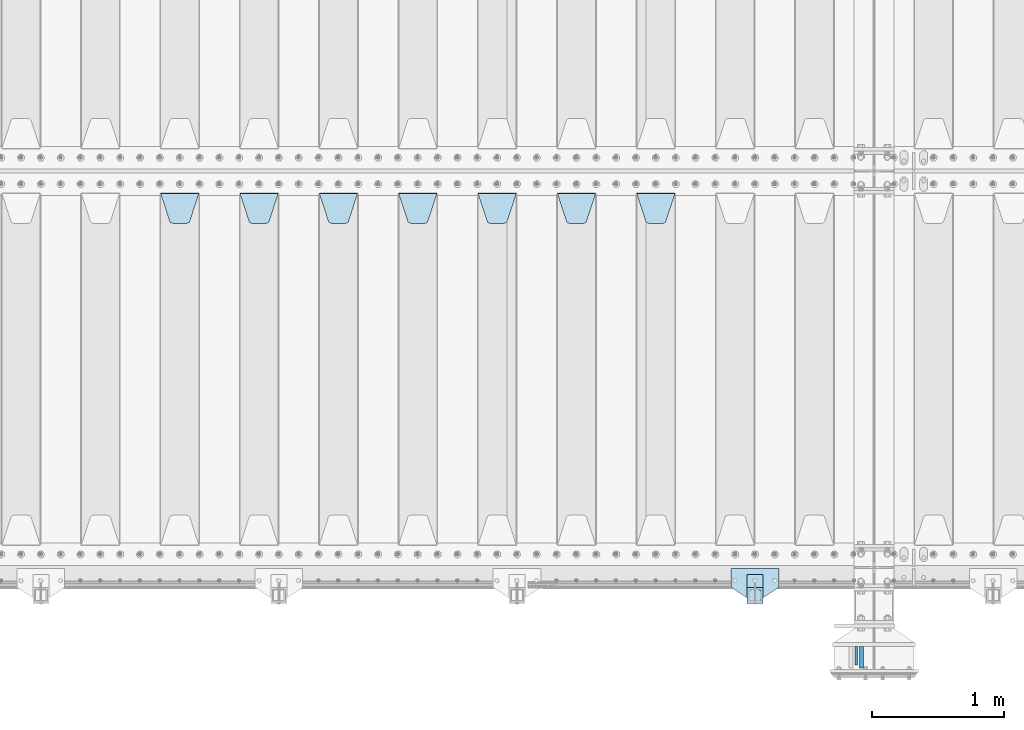
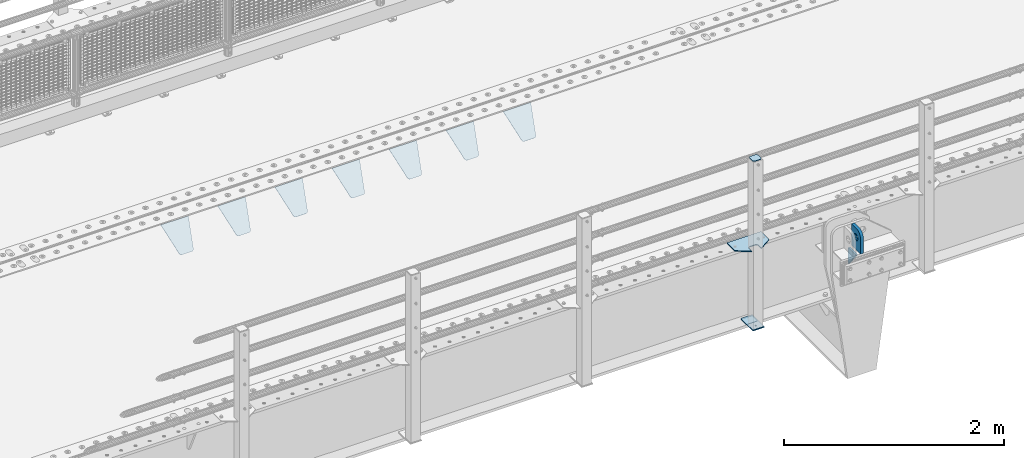
# One storey, part 177 of 208: 13 plates.
"""IFC2X3 building model written with IfcOpenShell, lengths in millimetres."""

from ifc_helpers import new_model, si_unit, frame, origin_with_axes, place, context, subcontext, project, spatial, faceted_brep, material, type_object, element, save


model = new_model("IFC2X3")

# Units and contexts
model_context = context("Model", 3, precision=1e-05, world=origin_with_axes())
body_context = subcontext(model_context, "Body", "Model", "MODEL_VIEW")
ifc_project = project(units=[si_unit("LENGTHUNIT", "METRE", prefix="MILLI"), si_unit("AREAUNIT", "SQUARE_METRE"), si_unit("VOLUMEUNIT", "CUBIC_METRE"), si_unit("MASSUNIT", "GRAM", prefix="KILO"), si_unit("TIMEUNIT", "SECOND"), si_unit("PLANEANGLEUNIT", "RADIAN"), si_unit("SOLIDANGLEUNIT", "STERADIAN"), si_unit("THERMODYNAMICTEMPERATUREUNIT", "DEGREE_CELSIUS"), si_unit("LUMINOUSINTENSITYUNIT", "LUMEN")], contexts=[model_context])

# Site, building, storey
site_placement = place(None, origin_with_axes())
site = spatial("IfcSite", under=ifc_project, at=site_placement, CompositionType="ELEMENT")
building_placement = place(site_placement, origin_with_axes())
building = spatial("IfcBuilding", under=site, at=building_placement, Name="Standard", CompositionType="ELEMENT")
storey_placement = place(building_placement, origin_with_axes())
storey = spatial("IfcBuildingStorey", under=building, at=storey_placement, Name="Undefined", CompositionType="ELEMENT", Elevation=0.0)

# Plates
ifc_material_1 = material(Name="STEEL/S355N")
plate_type_1 = type_object("IfcPlateType", PredefinedType="NOTDEFINED")
plate_1_placement = place(storey_placement, frame((-30335.5000001149, -734.999999963963, -14.0000182219301), z_axis=(0.0, 0.0, -1.0), x_axis=(0.0, 1.0, 0.0)))
element("IfcPlate", 1, at=plate_1_placement, inside=storey, type_object=plate_type_1, material=ifc_material_1, context=body_context, shape_type="Brep", body=[
    faceted_brep([(0.0, -10.0, 0.0), (140.0, -10.0, 180.0), (140.0, 10.0, 180.0), (0.0, 10.0, 0.0), (140.0, -10.0, -1.81898940354586e-12), (140.0, 10.0, -1.81898940354586e-12)], [[[0, 1, 2, 3]], [[1, 4, 5, 2]], [[4, 0, 3, 5]], [[5, 3, 2]], [[4, 1, 0]]]),
])
plate_type_2 = type_object("IfcPlateType", PredefinedType="NOTDEFINED")
plate_2_placement = place(storey_placement, frame((-30295.5000001165, -594.999999963945, -1.82219628186431e-05), z_axis=(0.0, -1.0, 0.0), x_axis=(0.0, 0.0, 1.0)))
element("IfcPlate", 2, at=plate_2_placement, inside=storey, type_object=plate_type_2, material=ifc_material_1, context=body_context, shape_type="Brep", body=[
    faceted_brep([(125.840713002497, -14.9999995435392, 45.8164574470834), (125.840713002497, 15.0000004564608, 45.8164571470834), (113.837049096103, 15.0000005366674, 53.8370489460988), (113.837049096103, -14.9999994633326, 53.8370492460988), (105.816457297088, 15.0000006567025, 65.8407128524926), (105.816457297088, -14.9999993432975, 65.8407131524926), (103.000000000005, 15.0000007982962, 79.999999850001), (103.000000000005, -14.9999992017038, 80.000000150001), (105.816457297088, 15.00000093989, 94.1592868475093), (105.816457297088, -14.99999906011, 94.1592871475093), (113.837049096103, 15.0000010599251, 106.162950753903), (113.837049096103, -14.9999989400749, 106.162951053903), (125.840713002497, 15.0000011401316, 114.183542552919), (125.840713002497, -14.9999988598684, 114.183542852919), (140.000000000005, 15.0000011682969, 116.999999850001), (140.000000000005, -14.9999988317031, 117.000000150001), (154.159286997514, 15.0000011401316, 114.183542552919), (154.159286997514, -14.9999988598684, 114.183542852919), (166.162950903908, 15.0000010599251, 106.162950753903), (166.162950903908, -14.9999989400749, 106.162951053903), (174.183542702923, 15.00000093989, 94.1592868475093), (174.183542702923, -14.99999906011, 94.1592871475093), (177.000000000005, 15.0000007982962, 79.999999850001), (177.000000000005, -14.9999992017038, 80.000000150001), (174.183542702923, 15.0000006567025, 65.8407128524927), (174.183542702923, -14.9999993432975, 65.8407131524928), (166.162950903908, 15.0000005366674, 53.8370489460988), (166.162950903908, -14.9999994633326, 53.8370492460988), (154.159286997514, 15.0000004564608, 45.8164571470834), (154.159286997514, -14.9999995435392, 45.8164574470834), (140.000000000005, 15.0000004282956, 42.999999850001), (140.000000000005, -14.9999995717044, 43.000000150001), (240.000015258789, -14.9999999999964, -2.06341610464733e-10), (240.001666876698, -15.0, 94.9959403776224), (237.616787699976, -15.0, 113.113322498935), (230.624045898169, -15.0, 129.996116868067), (219.499985670386, -14.9999999999964, 144.493787979863), (205.002693976271, -14.9999999999964, 155.618342674451), (188.120138118986, -15.0, 162.611660295065), (170.002837349484, -15.0, 164.997157401461), (-1.40620068123098e-06, -15.0, 165.0), (0.0, -15.0, 0.0), (0.0, 15.0, 0.0), (240.000015258789, 15.0000000000036, -2.06341610464733e-10), (240.001666876698, 15.0, 94.9959403776223), (237.616787699976, 15.0, 113.113322498935), (230.624045898169, 15.0, 129.996116868067), (219.499985670386, 15.0000000000036, 144.493787979863), (205.002693976271, 15.0000000000036, 155.618342674451), (188.120138118986, 15.0, 162.611660295065), (170.002837349484, 15.0, 164.997157401461), (-1.40620068123098e-06, 15.0, 165.0)], [[[0, 1, 2, 3]], [[3, 2, 4, 5]], [[5, 4, 6, 7]], [[7, 6, 8, 9]], [[9, 8, 10, 11]], [[11, 10, 12, 13]], [[13, 12, 14, 15]], [[15, 14, 16, 17]], [[17, 16, 18, 19]], [[19, 18, 20, 21]], [[21, 20, 22, 23]], [[23, 22, 24, 25]], [[25, 24, 26, 27]], [[27, 26, 28, 29]], [[29, 28, 30, 31]], [[31, 30, 1, 0]], [[32, 33, 34, 35, 36, 37, 38, 39, 40, 41], [3, 5, 7, 9, 11, 13, 15, 17, 19, 21, 23, 25, 27, 29, 31, 0]], [[32, 41, 42, 43]], [[33, 32, 43, 44]], [[34, 33, 44, 45]], [[35, 34, 45, 46]], [[36, 35, 46, 47]], [[37, 36, 47, 48]], [[38, 37, 48, 49]], [[39, 38, 49, 50]], [[40, 39, 50, 51]], [[41, 40, 51, 42]], [[50, 49, 48, 47, 46, 45, 44, 43, 42, 51], [26, 24, 22, 20, 18, 16, 14, 12, 10, 8, 6, 4, 2, 1, 30, 28]]]),
])
plate_type_3 = type_object("IfcPlateType", PredefinedType="NOTDEFINED")
plate_3_placement = place(storey_placement, frame((-31995.0, 2831.76776695596, -1.76776695296758), z_axis=(0.0, -0.707106781186548, -0.707106781186547), x_axis=(1.0, 0.0, 0.0)))
element("IfcPlate", 3, at=plate_3_placement, inside=storey, type_object=plate_type_3, material=ifc_material_1, context=body_context, shape_type="Brep", body=[
    faceted_brep([(0.0, -2.5, 0.0), (69.345504679477, -2.5, 300.17173142483), (69.345504679477, 2.5, 300.17173142483), (0.0, 2.5, 0.0), (70.9274061199576, -2.5, 304.897442415399), (70.9274061199576, 2.5, 304.8974424154), (73.3818627772307, -2.5, 309.234538108527), (73.3818627772307, 2.5, 309.234538108527), (76.6187032999551, -2.5, 313.023683126103), (76.6187032999551, 2.5, 313.023683126103), (80.5190132704993, -2.5, 316.125672595371), (80.5190132704993, 2.5, 316.125672595371), (84.9395038596849, -2.5, 318.426546230476), (84.9395038596849, 2.50000000000091, 318.426546230476), (89.7177759439219, -2.5, 319.841774983275), (89.7177759439219, 2.50000000000091, 319.841774983275), (94.678286292652, -2.49999999999909, 320.319366455078), (94.678286292652, 2.5, 320.319366455078), (195.321713707348, -2.49999999999909, 320.319366455078), (195.321713707348, 2.5, 320.319366455078), (200.282224056078, -2.5, 319.841774983275), (200.282224056078, 2.5, 319.841774983274), (205.060496140315, -2.5, 318.426546230475), (205.060496140315, 2.5, 318.426546230475), (209.480986729501, -2.5, 316.125672595371), (209.480986729501, 2.50000000000091, 316.125672595371), (213.381296700045, -2.5, 313.023683126102), (213.381296700045, 2.5, 313.023683126102), (216.618137222769, -2.5, 309.234538108526), (216.618137222769, 2.5, 309.234538108527), (219.072593880042, -2.5, 304.897442415399), (219.072593880042, 2.5, 304.897442415399), (220.654495320523, -2.5, 300.17173142483), (220.654495320523, 2.5, 300.17173142483), (290.0, -2.5, 0.0), (290.0, 2.5, 0.0)], [[[0, 1, 2, 3]], [[1, 4, 5, 2]], [[4, 6, 7, 5]], [[6, 8, 9, 7]], [[8, 10, 11, 9]], [[10, 12, 13, 11]], [[12, 14, 15, 13]], [[14, 16, 17, 15]], [[16, 18, 19, 17]], [[18, 20, 21, 19]], [[20, 22, 23, 21]], [[22, 24, 25, 23]], [[24, 26, 27, 25]], [[26, 28, 29, 27]], [[28, 30, 31, 29]], [[30, 32, 33, 31]], [[32, 34, 35, 33]], [[34, 0, 3, 35]], [[5, 7, 9, 11, 13, 15, 17, 19, 21, 23, 25, 27, 29, 31, 33, 35, 3, 2]], [[34, 32, 30, 28, 26, 24, 22, 20, 18, 16, 14, 12, 10, 8, 6, 4, 1, 0]]]),
])
plate_4_placement = place(storey_placement, frame((-32595.0, 2831.76776695596, -1.76776695296758), z_axis=(0.0, -0.707106781186548, -0.707106781186547), x_axis=(1.0, 0.0, 0.0)))
element("IfcPlate", 4, at=plate_4_placement, inside=storey, type_object=plate_type_3, material=ifc_material_1, context=body_context, shape_type="Brep", body=[
    faceted_brep([(0.0, -2.5, 0.0), (69.345504679477, -2.5, 300.17173142483), (69.345504679477, 2.5, 300.17173142483), (0.0, 2.5, 0.0), (70.9274061199576, -2.5, 304.897442415399), (70.9274061199576, 2.5, 304.8974424154), (73.3818627772307, -2.5, 309.234538108527), (73.3818627772307, 2.5, 309.234538108527), (76.6187032999551, -2.5, 313.023683126103), (76.6187032999551, 2.5, 313.023683126103), (80.5190132704993, -2.5, 316.125672595371), (80.5190132704993, 2.5, 316.125672595371), (84.9395038596849, -2.5, 318.426546230476), (84.9395038596849, 2.50000000000091, 318.426546230476), (89.7177759439219, -2.5, 319.841774983275), (89.7177759439219, 2.50000000000091, 319.841774983275), (94.678286292652, -2.49999999999909, 320.319366455078), (94.678286292652, 2.5, 320.319366455078), (195.321713707348, -2.49999999999909, 320.319366455078), (195.321713707348, 2.5, 320.319366455078), (200.282224056078, -2.5, 319.841774983275), (200.282224056078, 2.5, 319.841774983274), (205.060496140315, -2.5, 318.426546230475), (205.060496140315, 2.5, 318.426546230475), (209.480986729501, -2.5, 316.125672595371), (209.480986729501, 2.50000000000091, 316.125672595371), (213.381296700045, -2.5, 313.023683126102), (213.381296700045, 2.5, 313.023683126102), (216.618137222769, -2.5, 309.234538108526), (216.618137222769, 2.5, 309.234538108527), (219.072593880042, -2.5, 304.897442415399), (219.072593880042, 2.5, 304.897442415399), (220.654495320523, -2.5, 300.17173142483), (220.654495320523, 2.5, 300.17173142483), (290.0, -2.5, 0.0), (290.0, 2.5, 0.0)], [[[0, 1, 2, 3]], [[1, 4, 5, 2]], [[4, 6, 7, 5]], [[6, 8, 9, 7]], [[8, 10, 11, 9]], [[10, 12, 13, 11]], [[12, 14, 15, 13]], [[14, 16, 17, 15]], [[16, 18, 19, 17]], [[18, 20, 21, 19]], [[20, 22, 23, 21]], [[22, 24, 25, 23]], [[24, 26, 27, 25]], [[26, 28, 29, 27]], [[28, 30, 31, 29]], [[30, 32, 33, 31]], [[32, 34, 35, 33]], [[34, 0, 3, 35]], [[5, 7, 9, 11, 13, 15, 17, 19, 21, 23, 25, 27, 29, 31, 33, 35, 3, 2]], [[34, 32, 30, 28, 26, 24, 22, 20, 18, 16, 14, 12, 10, 8, 6, 4, 1, 0]]]),
])
plate_5_placement = place(storey_placement, frame((-33195.0, 2831.76776695596, -1.76776695296758), z_axis=(0.0, -0.707106781186548, -0.707106781186547), x_axis=(1.0, 0.0, 0.0)))
element("IfcPlate", 5, at=plate_5_placement, inside=storey, type_object=plate_type_3, material=ifc_material_1, context=body_context, shape_type="Brep", body=[
    faceted_brep([(0.0, -2.5, 0.0), (69.345504679477, -2.5, 300.17173142483), (69.345504679477, 2.5, 300.17173142483), (0.0, 2.5, 0.0), (70.9274061199576, -2.5, 304.897442415399), (70.9274061199576, 2.5, 304.8974424154), (73.3818627772307, -2.5, 309.234538108527), (73.3818627772307, 2.5, 309.234538108527), (76.6187032999551, -2.5, 313.023683126103), (76.6187032999551, 2.5, 313.023683126103), (80.5190132704993, -2.5, 316.125672595371), (80.5190132704993, 2.5, 316.125672595371), (84.9395038596849, -2.5, 318.426546230476), (84.9395038596849, 2.50000000000091, 318.426546230476), (89.7177759439219, -2.5, 319.841774983275), (89.7177759439219, 2.50000000000091, 319.841774983275), (94.678286292652, -2.49999999999909, 320.319366455078), (94.678286292652, 2.5, 320.319366455078), (195.321713707348, -2.49999999999909, 320.319366455078), (195.321713707348, 2.5, 320.319366455078), (200.282224056078, -2.5, 319.841774983275), (200.282224056078, 2.5, 319.841774983274), (205.060496140315, -2.5, 318.426546230475), (205.060496140315, 2.5, 318.426546230475), (209.480986729501, -2.5, 316.125672595371), (209.480986729501, 2.50000000000091, 316.125672595371), (213.381296700045, -2.5, 313.023683126102), (213.381296700045, 2.5, 313.023683126102), (216.618137222769, -2.5, 309.234538108526), (216.618137222769, 2.5, 309.234538108527), (219.072593880042, -2.5, 304.897442415399), (219.072593880042, 2.5, 304.897442415399), (220.654495320523, -2.5, 300.17173142483), (220.654495320523, 2.5, 300.17173142483), (290.0, -2.5, 0.0), (290.0, 2.5, 0.0)], [[[0, 1, 2, 3]], [[1, 4, 5, 2]], [[4, 6, 7, 5]], [[6, 8, 9, 7]], [[8, 10, 11, 9]], [[10, 12, 13, 11]], [[12, 14, 15, 13]], [[14, 16, 17, 15]], [[16, 18, 19, 17]], [[18, 20, 21, 19]], [[20, 22, 23, 21]], [[22, 24, 25, 23]], [[24, 26, 27, 25]], [[26, 28, 29, 27]], [[28, 30, 31, 29]], [[30, 32, 33, 31]], [[32, 34, 35, 33]], [[34, 0, 3, 35]], [[5, 7, 9, 11, 13, 15, 17, 19, 21, 23, 25, 27, 29, 31, 33, 35, 3, 2]], [[34, 32, 30, 28, 26, 24, 22, 20, 18, 16, 14, 12, 10, 8, 6, 4, 1, 0]]]),
])
plate_6_placement = place(storey_placement, frame((-33795.0, 2831.76776695596, -1.76776695296758), z_axis=(0.0, -0.707106781186548, -0.707106781186547), x_axis=(1.0, 0.0, 0.0)))
element("IfcPlate", 6, at=plate_6_placement, inside=storey, type_object=plate_type_3, material=ifc_material_1, context=body_context, shape_type="Brep", body=[
    faceted_brep([(0.0, -2.5, 0.0), (69.345504679477, -2.5, 300.17173142483), (69.345504679477, 2.5, 300.17173142483), (0.0, 2.5, 0.0), (70.9274061199576, -2.5, 304.897442415399), (70.9274061199576, 2.5, 304.8974424154), (73.3818627772307, -2.5, 309.234538108527), (73.3818627772307, 2.5, 309.234538108527), (76.6187032999551, -2.5, 313.023683126103), (76.6187032999551, 2.5, 313.023683126103), (80.5190132704993, -2.5, 316.125672595371), (80.5190132704993, 2.5, 316.125672595371), (84.9395038596849, -2.5, 318.426546230476), (84.9395038596849, 2.50000000000091, 318.426546230476), (89.7177759439219, -2.5, 319.841774983275), (89.7177759439219, 2.50000000000091, 319.841774983275), (94.678286292652, -2.49999999999909, 320.319366455078), (94.678286292652, 2.5, 320.319366455078), (195.321713707348, -2.49999999999909, 320.319366455078), (195.321713707348, 2.5, 320.319366455078), (200.282224056078, -2.5, 319.841774983275), (200.282224056078, 2.5, 319.841774983274), (205.060496140315, -2.5, 318.426546230475), (205.060496140315, 2.5, 318.426546230475), (209.480986729501, -2.5, 316.125672595371), (209.480986729501, 2.50000000000091, 316.125672595371), (213.381296700045, -2.5, 313.023683126102), (213.381296700045, 2.5, 313.023683126102), (216.618137222769, -2.5, 309.234538108526), (216.618137222769, 2.5, 309.234538108527), (219.072593880042, -2.5, 304.897442415399), (219.072593880042, 2.5, 304.897442415399), (220.654495320523, -2.5, 300.17173142483), (220.654495320523, 2.5, 300.17173142483), (290.0, -2.5, 0.0), (290.0, 2.5, 0.0)], [[[0, 1, 2, 3]], [[1, 4, 5, 2]], [[4, 6, 7, 5]], [[6, 8, 9, 7]], [[8, 10, 11, 9]], [[10, 12, 13, 11]], [[12, 14, 15, 13]], [[14, 16, 17, 15]], [[16, 18, 19, 17]], [[18, 20, 21, 19]], [[20, 22, 23, 21]], [[22, 24, 25, 23]], [[24, 26, 27, 25]], [[26, 28, 29, 27]], [[28, 30, 31, 29]], [[30, 32, 33, 31]], [[32, 34, 35, 33]], [[34, 0, 3, 35]], [[5, 7, 9, 11, 13, 15, 17, 19, 21, 23, 25, 27, 29, 31, 33, 35, 3, 2]], [[34, 32, 30, 28, 26, 24, 22, 20, 18, 16, 14, 12, 10, 8, 6, 4, 1, 0]]]),
])
plate_7_placement = place(storey_placement, frame((-34395.0, 2831.76776695596, -1.76776695296758), z_axis=(0.0, -0.707106781186548, -0.707106781186547), x_axis=(1.0, 0.0, 0.0)))
element("IfcPlate", 7, at=plate_7_placement, inside=storey, type_object=plate_type_3, material=ifc_material_1, context=body_context, shape_type="Brep", body=[
    faceted_brep([(0.0, -2.5, 0.0), (69.345504679477, -2.5, 300.17173142483), (69.345504679477, 2.5, 300.17173142483), (0.0, 2.5, 0.0), (70.9274061199576, -2.5, 304.897442415399), (70.9274061199576, 2.5, 304.8974424154), (73.3818627772307, -2.5, 309.234538108527), (73.3818627772307, 2.5, 309.234538108527), (76.6187032999551, -2.5, 313.023683126103), (76.6187032999551, 2.5, 313.023683126103), (80.5190132704993, -2.5, 316.125672595371), (80.5190132704993, 2.5, 316.125672595371), (84.9395038596849, -2.5, 318.426546230476), (84.9395038596849, 2.50000000000091, 318.426546230476), (89.7177759439219, -2.5, 319.841774983275), (89.7177759439219, 2.50000000000091, 319.841774983275), (94.678286292652, -2.49999999999909, 320.319366455078), (94.678286292652, 2.5, 320.319366455078), (195.321713707348, -2.49999999999909, 320.319366455078), (195.321713707348, 2.5, 320.319366455078), (200.282224056078, -2.5, 319.841774983275), (200.282224056078, 2.5, 319.841774983274), (205.060496140315, -2.5, 318.426546230475), (205.060496140315, 2.5, 318.426546230475), (209.480986729501, -2.5, 316.125672595371), (209.480986729501, 2.50000000000091, 316.125672595371), (213.381296700045, -2.5, 313.023683126102), (213.381296700045, 2.5, 313.023683126102), (216.618137222769, -2.5, 309.234538108526), (216.618137222769, 2.5, 309.234538108527), (219.072593880042, -2.5, 304.897442415399), (219.072593880042, 2.5, 304.897442415399), (220.654495320523, -2.5, 300.17173142483), (220.654495320523, 2.5, 300.17173142483), (290.0, -2.5, 0.0), (290.0, 2.5, 0.0)], [[[0, 1, 2, 3]], [[1, 4, 5, 2]], [[4, 6, 7, 5]], [[6, 8, 9, 7]], [[8, 10, 11, 9]], [[10, 12, 13, 11]], [[12, 14, 15, 13]], [[14, 16, 17, 15]], [[16, 18, 19, 17]], [[18, 20, 21, 19]], [[20, 22, 23, 21]], [[22, 24, 25, 23]], [[24, 26, 27, 25]], [[26, 28, 29, 27]], [[28, 30, 31, 29]], [[30, 32, 33, 31]], [[32, 34, 35, 33]], [[34, 0, 3, 35]], [[5, 7, 9, 11, 13, 15, 17, 19, 21, 23, 25, 27, 29, 31, 33, 35, 3, 2]], [[34, 32, 30, 28, 26, 24, 22, 20, 18, 16, 14, 12, 10, 8, 6, 4, 1, 0]]]),
])
plate_8_placement = place(storey_placement, frame((-34995.0, 2831.76776695596, -1.76776695296758), z_axis=(0.0, -0.707106781186548, -0.707106781186547), x_axis=(1.0, 0.0, 0.0)))
element("IfcPlate", 8, at=plate_8_placement, inside=storey, type_object=plate_type_3, material=ifc_material_1, context=body_context, shape_type="Brep", body=[
    faceted_brep([(0.0, -2.5, 0.0), (69.345504679477, -2.5, 300.17173142483), (69.345504679477, 2.5, 300.17173142483), (0.0, 2.5, 0.0), (70.9274061199576, -2.5, 304.897442415399), (70.9274061199576, 2.5, 304.8974424154), (73.3818627772307, -2.5, 309.234538108527), (73.3818627772307, 2.5, 309.234538108527), (76.6187032999551, -2.5, 313.023683126103), (76.6187032999551, 2.5, 313.023683126103), (80.5190132704993, -2.5, 316.125672595371), (80.5190132704993, 2.5, 316.125672595371), (84.9395038596849, -2.5, 318.426546230476), (84.9395038596849, 2.50000000000091, 318.426546230476), (89.7177759439219, -2.5, 319.841774983275), (89.7177759439219, 2.50000000000091, 319.841774983275), (94.678286292652, -2.49999999999909, 320.319366455078), (94.678286292652, 2.5, 320.319366455078), (195.321713707348, -2.49999999999909, 320.319366455078), (195.321713707348, 2.5, 320.319366455078), (200.282224056078, -2.5, 319.841774983275), (200.282224056078, 2.5, 319.841774983274), (205.060496140315, -2.5, 318.426546230475), (205.060496140315, 2.5, 318.426546230475), (209.480986729501, -2.5, 316.125672595371), (209.480986729501, 2.50000000000091, 316.125672595371), (213.381296700045, -2.5, 313.023683126102), (213.381296700045, 2.5, 313.023683126102), (216.618137222769, -2.5, 309.234538108526), (216.618137222769, 2.5, 309.234538108527), (219.072593880042, -2.5, 304.897442415399), (219.072593880042, 2.5, 304.897442415399), (220.654495320523, -2.5, 300.17173142483), (220.654495320523, 2.5, 300.17173142483), (290.0, -2.5, 0.0), (290.0, 2.5, 0.0)], [[[0, 1, 2, 3]], [[1, 4, 5, 2]], [[4, 6, 7, 5]], [[6, 8, 9, 7]], [[8, 10, 11, 9]], [[10, 12, 13, 11]], [[12, 14, 15, 13]], [[14, 16, 17, 15]], [[16, 18, 19, 17]], [[18, 20, 21, 19]], [[20, 22, 23, 21]], [[22, 24, 25, 23]], [[24, 26, 27, 25]], [[26, 28, 29, 27]], [[28, 30, 31, 29]], [[30, 32, 33, 31]], [[32, 34, 35, 33]], [[34, 0, 3, 35]], [[5, 7, 9, 11, 13, 15, 17, 19, 21, 23, 25, 27, 29, 31, 33, 35, 3, 2]], [[34, 32, 30, 28, 26, 24, 22, 20, 18, 16, 14, 12, 10, 8, 6, 4, 1, 0]]]),
])
plate_9_placement = place(storey_placement, frame((-35595.0, 2831.76776695596, -1.76776695296758), z_axis=(0.0, -0.707106781186548, -0.707106781186547), x_axis=(1.0, 0.0, 0.0)))
element("IfcPlate", 9, at=plate_9_placement, inside=storey, type_object=plate_type_3, material=ifc_material_1, context=body_context, shape_type="Brep", body=[
    faceted_brep([(0.0, -2.5, 0.0), (69.345504679477, -2.5, 300.17173142483), (69.345504679477, 2.5, 300.17173142483), (0.0, 2.5, 0.0), (70.9274061199576, -2.5, 304.897442415399), (70.9274061199576, 2.5, 304.8974424154), (73.3818627772307, -2.5, 309.234538108527), (73.3818627772307, 2.5, 309.234538108527), (76.6187032999551, -2.5, 313.023683126103), (76.6187032999551, 2.5, 313.023683126103), (80.5190132704993, -2.5, 316.125672595371), (80.5190132704993, 2.5, 316.125672595371), (84.9395038596849, -2.5, 318.426546230476), (84.9395038596849, 2.50000000000091, 318.426546230476), (89.7177759439219, -2.5, 319.841774983275), (89.7177759439219, 2.50000000000091, 319.841774983275), (94.678286292652, -2.49999999999909, 320.319366455078), (94.678286292652, 2.5, 320.319366455078), (195.321713707348, -2.49999999999909, 320.319366455078), (195.321713707348, 2.5, 320.319366455078), (200.282224056078, -2.5, 319.841774983275), (200.282224056078, 2.5, 319.841774983274), (205.060496140315, -2.5, 318.426546230475), (205.060496140315, 2.5, 318.426546230475), (209.480986729501, -2.5, 316.125672595371), (209.480986729501, 2.50000000000091, 316.125672595371), (213.381296700045, -2.5, 313.023683126102), (213.381296700045, 2.5, 313.023683126102), (216.618137222769, -2.5, 309.234538108526), (216.618137222769, 2.5, 309.234538108527), (219.072593880042, -2.5, 304.897442415399), (219.072593880042, 2.5, 304.897442415399), (220.654495320523, -2.5, 300.17173142483), (220.654495320523, 2.5, 300.17173142483), (290.0, -2.5, 0.0), (290.0, 2.5, 0.0)], [[[0, 1, 2, 3]], [[1, 4, 5, 2]], [[4, 6, 7, 5]], [[6, 8, 9, 7]], [[8, 10, 11, 9]], [[10, 12, 13, 11]], [[12, 14, 15, 13]], [[14, 16, 17, 15]], [[16, 18, 19, 17]], [[18, 20, 21, 19]], [[20, 22, 23, 21]], [[22, 24, 25, 23]], [[24, 26, 27, 25]], [[26, 28, 29, 27]], [[28, 30, 31, 29]], [[30, 32, 33, 31]], [[32, 34, 35, 33]], [[34, 0, 3, 35]], [[5, 7, 9, 11, 13, 15, 17, 19, 21, 23, 25, 27, 29, 31, 33, 35, 3, 2]], [[34, 32, 30, 28, 26, 24, 22, 20, 18, 16, 14, 12, 10, 8, 6, 4, 1, 0]]]),
])
ifc_material_2 = material(Name="STEEL/S355J2")
plate_type_4 = type_object("IfcPlateType", PredefinedType="NOTDEFINED")
plate_10_placement = place(storey_placement, frame((-30920.0, -4.99999999999636, 5.00000000004911), z_axis=(0.0, -1.0, 0.0), x_axis=(-1.0, 0.0, 0.0)))
element("IfcPlate", 10, at=plate_10_placement, inside=storey, type_object=plate_type_4, material=ifc_material_2, context=body_context, shape_type="Brep", body=[
    faceted_brep([(0.0, -5.0, 0.0), (2.31396552408114e-06, -5.0, 145.0), (2.31396552408114e-06, 5.0, 145.0), (0.0, 5.0, 0.0), (130.0, -5.0, 230.0), (130.0, 5.0, 230.0), (130.0, -5.0, 180.0), (130.0, 5.0, 180.0), (130.48036798992, -5.0, 175.122741949597), (130.48036798992, 5.0, 175.122741949597), (131.903011687216, -5.0, 170.432914190873), (131.903011687216, 5.0, 170.432914190873), (134.213259692435, -5.0, 166.11074417451), (134.213259692435, 5.0, 166.11074417451), (137.322330470335, -5.0, 162.322330470336), (137.322330470335, 5.0, 162.322330470336), (141.110744174512, -5.0, 159.213259692437), (141.110744174512, 5.0, 159.213259692437), (145.432914190871, -5.0, 156.903011687218), (145.432914190871, 5.0, 156.903011687218), (150.122741949595, -5.0, 155.48036798992), (150.122741949595, 5.0, 155.48036798992), (155.0, -5.0, 155.0), (155.0, 5.0, 155.0), (205.0, -5.0, 155.0), (205.0, 5.0, 155.0), (209.877258050405, -5.0, 155.48036798992), (209.877258050405, 5.0, 155.48036798992), (214.567085809129, -5.0, 156.903011687218), (214.567085809129, 5.0, 156.903011687218), (218.889255825488, -5.0, 159.213259692437), (218.889255825488, 5.0, 159.213259692437), (222.677669529665, -5.0, 162.322330470336), (222.677669529665, 5.0, 162.322330470336), (225.786740307565, -5.0, 166.11074417451), (225.786740307565, 5.0, 166.11074417451), (228.096988312784, -5.0, 170.432914190873), (228.096988312784, 5.0, 170.432914190873), (229.51963201008, -5.0, 175.122741949597), (229.51963201008, 5.0, 175.122741949597), (230.0, -5.0, 180.0), (230.0, 5.0, 180.0), (230.0, -5.0, 230.0), (230.0, 5.0, 230.0), (360.0, -5.0, 145.0), (360.0, 5.0, 145.0), (360.0, -5.0, -7.27595761418343e-12), (360.0, 5.0, -7.27595761418343e-12)], [[[0, 1, 2, 3]], [[1, 4, 5, 2]], [[4, 6, 7, 5]], [[6, 8, 9, 7]], [[8, 10, 11, 9]], [[10, 12, 13, 11]], [[12, 14, 15, 13]], [[14, 16, 17, 15]], [[16, 18, 19, 17]], [[18, 20, 21, 19]], [[20, 22, 23, 21]], [[22, 24, 25, 23]], [[24, 26, 27, 25]], [[26, 28, 29, 27]], [[28, 30, 31, 29]], [[30, 32, 33, 31]], [[32, 34, 35, 33]], [[34, 36, 37, 35]], [[36, 38, 39, 37]], [[38, 40, 41, 39]], [[40, 42, 43, 41]], [[42, 44, 45, 43]], [[44, 46, 47, 45]], [[46, 0, 3, 47]], [[5, 7, 9, 11, 13, 15, 17, 19, 21, 23, 25, 27, 29, 31, 33, 35, 37, 39, 41, 43, 45, 47, 3, 2]], [[46, 44, 42, 40, 38, 36, 34, 32, 30, 28, 26, 24, 22, 20, 18, 16, 14, 12, 10, 8, 6, 4, 1, 0]]]),
])
plate_type_5 = type_object("IfcPlateType", PredefinedType="NOTDEFINED")
plate_11_placement = place(storey_placement, frame((-31040.0000000001, -50.0000000002074, -850.000000000002), z_axis=(0.0, -1.0, 0.0), x_axis=(-1.0, 0.0, 0.0)))
element("IfcPlate", 11, at=plate_11_placement, inside=storey, type_object=plate_type_5, material=ifc_material_2, context=body_context, shape_type="Brep", body=[
    faceted_brep([(53.6360389691836, -5.0, 176.36396103047), (53.6360389691836, 5.0, 176.36396103047), (59.9999999998618, 5.0, 178.999999999791), (59.9999999998618, -5.0, 178.999999999791), (66.3639610305399, 5.0, 176.36396103047), (66.3639610305399, -5.0, 176.36396103047), (68.9999999998618, 5.0, 169.999999999791), (68.9999999998618, -5.0, 169.999999999791), (66.3639610305399, 5.0, 163.636038969112), (66.3639610305399, -5.0, 163.636038969112), (59.9999999998618, 5.0, 160.999999999791), (59.9999999998618, -5.0, 160.999999999791), (53.6360389691836, 5.0, 163.636038969112), (53.6360389691836, -5.0, 163.636038969112), (50.9999999998618, 5.0, 169.999999999791), (50.9999999998618, -5.0, 169.999999999791), (120.0, -5.0, 0.0), (120.0, -5.0, 220.0), (0.0, -5.0, 220.0), (0.0, -5.0, 0.0), (0.0, 5.0, 0.0), (120.0, 5.0, 0.0), (120.0, 5.0, 220.0), (0.0, 5.0, 220.0)], [[[0, 1, 2, 3]], [[3, 2, 4, 5]], [[5, 4, 6, 7]], [[7, 6, 8, 9]], [[9, 8, 10, 11]], [[11, 10, 12, 13]], [[13, 12, 14, 15]], [[15, 14, 1, 0]], [[16, 17, 18, 19], [11, 13, 15, 0, 3, 5, 7, 9]], [[16, 19, 20, 21]], [[17, 16, 21, 22]], [[18, 17, 22, 23]], [[19, 18, 23, 20]], [[22, 21, 20, 23], [2, 1, 14, 12, 10, 8, 6, 4]]]),
])
plate_type_6 = type_object("IfcPlateType", PredefinedType="NOTDEFINED")
plate_12_placement = place(storey_placement, frame((-31144.0000000001, -166.000000000207, 1012.50000000001), z_axis=(0.0, -1.0, 0.0), x_axis=(1.0, 0.0, 0.0)))
element("IfcPlate", 12, at=plate_12_placement, inside=storey, type_object=plate_type_6, material=ifc_material_2, context=body_context, shape_type="Brep", body=[
    faceted_brep([(0.0, -2.5, 19.0), (0.0, -2.5, 69.0), (0.0, 2.5, 69.0), (0.0, 2.5, 19.0), (0.476369668544066, -2.5, 73.2278977451697), (0.476369668544066, 2.5, 73.2278977451697), (1.88159150985302, -2.5, 77.2437910432336), (1.88159150985302, 2.5, 77.2437910432336), (4.14520183310742, -2.5, 80.8463062353158), (4.14520183310742, 2.5, 80.8463062353158), (7.15369376468516, -2.5, 83.8547981668926), (7.15369376468516, 2.5, 83.8547981668926), (10.7562089567655, -2.5, 86.1184084901461), (10.7562089567655, 2.5, 86.1184084901461), (14.7721022548285, -2.5, 87.523630331455), (14.7721022548285, 2.5, 87.523630331455), (19.0, -2.5, 88.0), (19.0, 2.5, 88.0), (69.0, -2.5, 88.0), (69.0, 2.5, 88.0), (73.2278977451715, -2.5, 87.523630331455), (73.2278977451715, 2.5, 87.523630331455), (77.2437910432345, -2.5, 86.1184084901461), (77.2437910432345, 2.5, 86.1184084901461), (80.8463062353148, -2.5, 83.8547981668926), (80.8463062353148, 2.5, 83.8547981668926), (83.8547981668926, -2.5, 80.8463062353158), (83.8547981668926, 2.5, 80.8463062353158), (86.118408490147, -2.5, 77.2437910432336), (86.118408490147, 2.5, 77.2437910432336), (87.5236303314559, -2.5, 73.2278977451697), (87.5236303314559, 2.5, 73.2278977451697), (88.0, -2.5, 69.0), (88.0, 2.5, 69.0), (88.0, -2.5, 19.0), (88.0, 2.5, 19.0), (87.5236303314559, -2.5, 14.7721022548303), (87.5236303314559, 2.5, 14.7721022548303), (86.118408490147, -2.5, 10.7562089567664), (86.118408490147, 2.5, 10.7562089567664), (83.8547981668926, -2.5, 7.15369376468425), (83.8547981668926, 2.5, 7.15369376468425), (80.8463062353148, -2.5, 4.14520183310742), (80.8463062353148, 2.5, 4.14520183310742), (77.2437910432345, -2.5, 1.88159150985393), (77.2437910432345, 2.5, 1.88159150985393), (73.2278977451715, -2.5, 0.476369668544976), (73.2278977451715, 2.5, 0.476369668544976), (69.0, -2.5, 0.0), (69.0, 2.5, 0.0), (19.0, -2.5, 0.0), (19.0, 2.5, 0.0), (14.7721022548285, -2.5, 0.476369668544976), (14.7721022548285, 2.5, 0.476369668544976), (10.7562089567655, -2.5, 1.88159150985393), (10.7562089567655, 2.5, 1.88159150985393), (7.15369376468516, -2.5, 4.14520183310742), (7.15369376468516, 2.5, 4.14520183310742), (4.14520183310742, -2.5, 7.15369376468425), (4.14520183310742, 2.5, 7.15369376468425), (1.88159150985302, -2.5, 10.7562089567664), (1.88159150985302, 2.5, 10.7562089567664), (0.476369668544066, -2.5, 14.7721022548303), (0.476369668544066, 2.5, 14.7721022548303)], [[[0, 1, 2, 3]], [[1, 4, 5, 2]], [[4, 6, 7, 5]], [[6, 8, 9, 7]], [[8, 10, 11, 9]], [[10, 12, 13, 11]], [[12, 14, 15, 13]], [[14, 16, 17, 15]], [[16, 18, 19, 17]], [[18, 20, 21, 19]], [[20, 22, 23, 21]], [[22, 24, 25, 23]], [[24, 26, 27, 25]], [[26, 28, 29, 27]], [[28, 30, 31, 29]], [[30, 32, 33, 31]], [[32, 34, 35, 33]], [[34, 36, 37, 35]], [[36, 38, 39, 37]], [[38, 40, 41, 39]], [[40, 42, 43, 41]], [[42, 44, 45, 43]], [[44, 46, 47, 45]], [[46, 48, 49, 47]], [[48, 50, 51, 49]], [[50, 52, 53, 51]], [[52, 54, 55, 53]], [[54, 56, 57, 55]], [[56, 58, 59, 57]], [[58, 60, 61, 59]], [[60, 62, 63, 61]], [[62, 0, 3, 63]], [[5, 7, 9, 11, 13, 15, 17, 19, 21, 23, 25, 27, 29, 31, 33, 35, 37, 39, 41, 43, 45, 47, 49, 51, 53, 55, 57, 59, 61, 63, 3, 2]], [[62, 60, 58, 56, 54, 52, 50, 48, 46, 44, 42, 40, 38, 36, 34, 32, 30, 28, 26, 24, 22, 20, 18, 16, 14, 12, 10, 8, 6, 4, 1, 0]]]),
])
plate_type_7 = type_object("IfcPlateType", PredefinedType="NOTDEFINED")
plate_13_placement = place(storey_placement, frame((-31040.0000000001, -50.0000000002074, -857.500000000002), z_axis=(0.0, -1.0, 0.0), x_axis=(-1.0, 0.0, 0.0)))
element("IfcPlate", 13, at=plate_13_placement, inside=storey, type_object=plate_type_7, material=ifc_material_2, context=body_context, shape_type="Brep", body=[
    faceted_brep([(0.0, -2.5, 0.0), (0.0, -2.5, 100.0), (0.0, 2.5, 100.0), (0.0, 2.5, 0.0), (120.0, -2.5, 100.0), (120.0, 2.5, 100.0), (120.0, -2.5, 0.0), (120.0, 2.5, 0.0)], [[[0, 1, 2, 3]], [[1, 4, 5, 2]], [[4, 6, 7, 5]], [[6, 0, 3, 7]], [[5, 7, 3, 2]], [[6, 4, 1, 0]]]),
])

save(model, "model.ifc")
